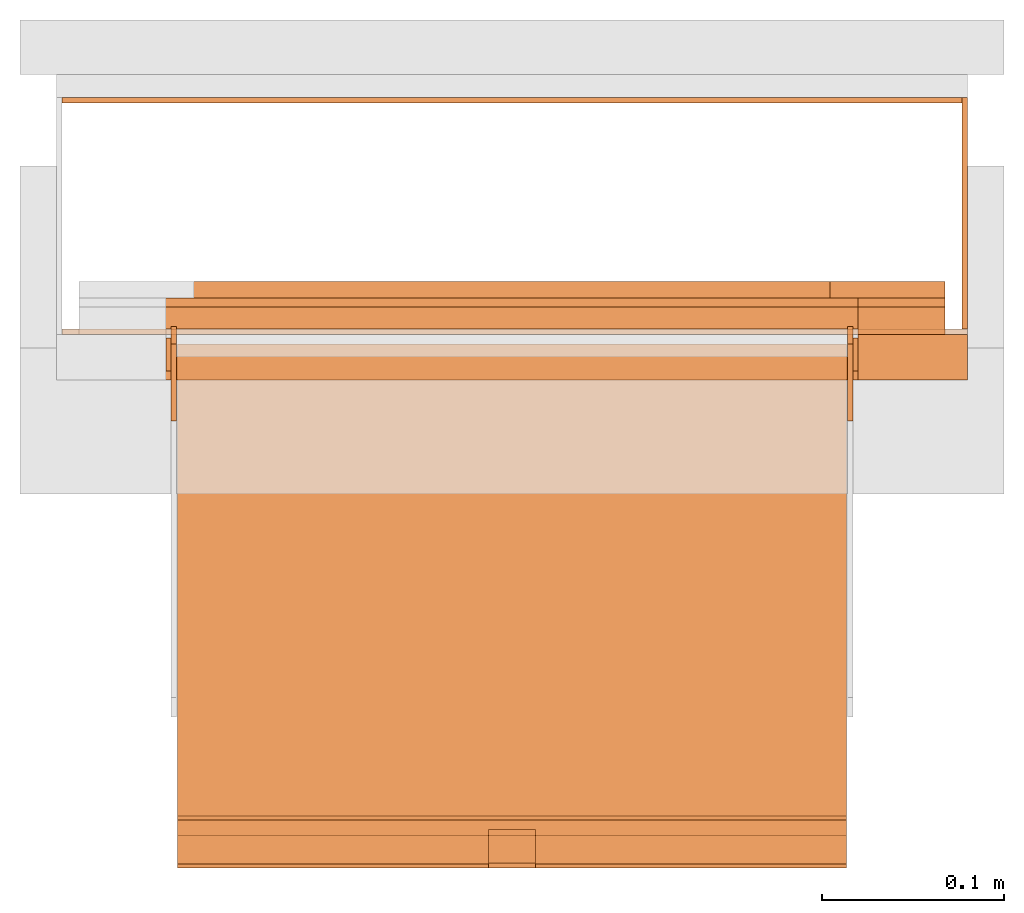
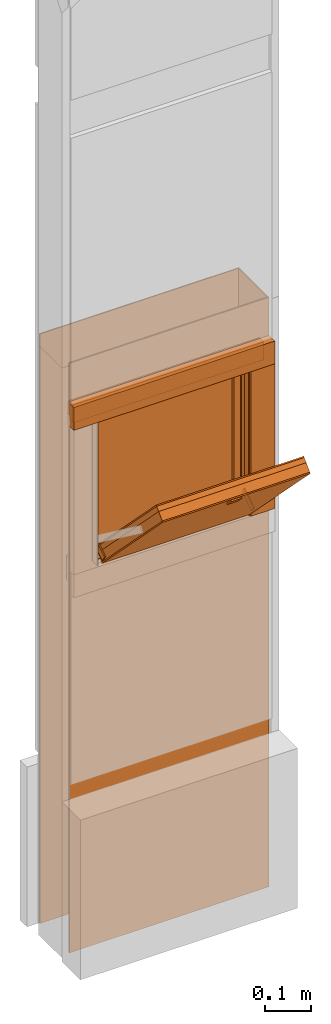
# One storey, part 2 of 3: 20 proxies, 1 opening.
"""IFC2X3 building model written with IfcOpenShell, lengths in metres."""

from ifc_helpers import new_model, entity, si_unit, converted_unit, derived_unit, money_unit, direction, frame, origin_with_axes, origin_2d_with_axis, place, context, subcontext, project, spatial, polyline, rectangle, outline, extrude, boolean, faceted_brep, source, transform, mapped, material, type_object, element, save


model = new_model("IFC2X3")

# Units and contexts
model_context = context("Model", 3, precision=1e-05, world=origin_with_axes(), true_north=direction((0.0, 1.0)))
plan_context = context("Plan", 3, precision=1e-05, world=origin_with_axes(), true_north=direction((0.0, 1.0)))
body_context = subcontext(model_context, "Body", "Model", "MODEL_VIEW")
ifc_project = project(units=[si_unit("LENGTHUNIT", "METRE"), si_unit("AREAUNIT", "SQUARE_METRE"), si_unit("VOLUMEUNIT", "CUBIC_METRE"), converted_unit("PLANEANGLEUNIT", "DEGREE", entity("IfcPlaneAngleMeasure", 0.0174532925199), si_unit("PLANEANGLEUNIT", "RADIAN"), dimensions=[0, 0, 0, 0, 0, 0, 0]), si_unit("SOLIDANGLEUNIT", "STERADIAN"), money_unit("CHF"), converted_unit("TIMEUNIT", "Year", entity("IfcTimeMeasure", 31556926.0), si_unit("TIMEUNIT", "SECOND"), dimensions=[0, 0, 1, 0, 0, 0, 0]), si_unit("MASSUNIT", "GRAM", prefix="KILO"), si_unit("THERMODYNAMICTEMPERATUREUNIT", "DEGREE_CELSIUS"), si_unit("LUMINOUSINTENSITYUNIT", "LUMEN"), si_unit("ENERGYUNIT", "JOULE", prefix="MEGA"), derived_unit("THERMALCONDUCTANCEUNIT", [(si_unit("POWERUNIT", "WATT"), 1), (si_unit("LENGTHUNIT", "METRE"), -1), (si_unit("THERMODYNAMICTEMPERATUREUNIT", "KELVIN"), -1)]), derived_unit("SPECIFICHEATCAPACITYUNIT", [(si_unit("ENERGYUNIT", "JOULE"), 1), (si_unit("MASSUNIT", "GRAM", prefix="KILO"), -1), (si_unit("THERMODYNAMICTEMPERATUREUNIT", "KELVIN"), -1)]), derived_unit("MASSDENSITYUNIT", [(si_unit("MASSUNIT", "GRAM", prefix="KILO"), 1), (si_unit("VOLUMEUNIT", "CUBIC_METRE"), -1)])], contexts=[model_context, plan_context])

# Site, building, storey
site_placement = place(None, origin_with_axes())
site = spatial("IfcSite", under=ifc_project, at=site_placement, CompositionType="ELEMENT")
building_placement = place(site_placement, origin_with_axes())
building = spatial("IfcBuilding", under=site, at=building_placement, CompositionType="ELEMENT")
storey_placement = place(building_placement, frame((0.0, 0.0, 2.96), z_axis=(0.0, 0.0, 1.0), x_axis=(1.0, 0.0, 0.0)))
storey = spatial("IfcBuildingStorey", under=building, at=storey_placement, Name="OG01", CompositionType="ELEMENT", Elevation=2.96)

# Proxies
ifc_material_1 = material(Name="Metall, Stahl")
building_element_proxy_type_1 = type_object("IfcBuildingElementProxyType", Name="Metall, Stahl 3", PredefinedType="NOTDEFINED")
proxy_1_placement = place(storey_placement, frame((9.61522436818, -8.09743070606, -0.4), z_axis=(0.0, 0.0, 1.0), x_axis=(-1.0, 0.0, 0.0)))
element("IfcBuildingElementProxy", 1, at=proxy_1_placement, inside=storey, type_object=building_element_proxy_type_1, material=ifc_material_1, Name="Wand-008", context=body_context, shape_type="CSG", body=[
    boolean("DIFFERENCE", boolean("DIFFERENCE", extrude(outline(polyline([(0.0, 0.0), (0.5, 0.0), (0.5, 0.003), (0.0, 0.003), (0.0, 0.0)])), origin_with_axes(), (0.0, 0.0, 1.0), 1.55), faceted_brep([(0.497, 0.003, 1.55), (0.497, 0.0, 1.55), (0.5, 0.0, 1.55), (0.5, 0.003, 1.55), (0.497, 0.0, 0.0), (0.497, 0.003, 0.0), (0.5, 0.0, 0.0), (0.5, 0.003, 0.0)], [[[0, 1, 2, 3]], [[4, 1, 0, 5]], [[1, 4, 6, 2]], [[2, 6, 7, 3]], [[5, 0, 3, 7]], [[4, 5, 7, 6]]])), faceted_brep([(0.003, 0.0, 0.0), (0.003, 0.0, 1.55), (0.0, 0.0, 1.55), (0.0, 0.0, 0.0), (0.003, 0.003, 1.55), (0.003, 0.003, 0.0), (0.0, 0.003, 1.55), (0.0, 0.003, 0.0)], [[[0, 1, 2, 3]], [[4, 1, 0, 5]], [[1, 4, 6, 2]], [[6, 7, 3, 2]], [[5, 0, 3, 7]], [[4, 5, 7, 6]]])),
])
proxy_2_placement = place(storey_placement, frame((9.61522436818, -8.22743070606, -0.4), z_axis=(0.0, 0.0, 1.0), x_axis=(0.0, 1.0, 0.0)))
element("IfcBuildingElementProxy", 2, at=proxy_2_placement, inside=storey, type_object=building_element_proxy_type_1, material=ifc_material_1, Name="Wand-007", context=body_context, shape_type="CSG", body=[
    boolean("DIFFERENCE", extrude(outline(polyline([(0.0, 0.0), (0.13, 0.0), (0.13, 0.003), (0.0, 0.003), (0.0, 0.0)])), origin_with_axes(), (0.0, 0.0, 1.0), 1.55), faceted_brep([(0.003, 0.0, 0.0), (0.003, 0.0, 1.55), (0.0, 0.0, 1.55), (0.0, 0.0, 0.0), (0.003, 0.003, 1.55), (0.003, 0.003, 0.0), (0.0, 0.003, 1.55), (0.0, 0.003, 0.0)], [[[0, 1, 2, 3]], [[4, 1, 0, 5]], [[1, 4, 6, 2]], [[6, 7, 3, 2]], [[5, 0, 3, 7]], [[4, 5, 7, 6]]])),
])

# Proxy, opening
proxy_3_placement = place(storey_placement, frame((9.11522436818, -8.22743070606, -0.4), z_axis=(0.0, 0.0, 1.0), x_axis=(1.0, 0.0, 0.0)))
proxy_3 = element("IfcBuildingElementProxy", 3, at=proxy_3_placement, inside=storey, type_object=building_element_proxy_type_1, material=ifc_material_1, Name="Wand-006", context=body_context, shape_type="CSG", body=[
    boolean("DIFFERENCE", extrude(outline(polyline([(0.0, 0.0), (0.5, 0.0), (0.5, 0.003), (0.0, 0.003), (0.0, 0.0)])), origin_with_axes(), (0.0, 0.0, 1.0), 1.55), faceted_brep([(0.003, 0.0, 1.55), (0.003, 0.003, 1.55), (0.0, 0.003, 1.55), (0.0, 0.0, 1.55), (0.003, 0.003, 0.0), (0.003, 0.0, 0.0), (0.0, 0.003, 0.0), (0.0, 0.0, 0.0)], [[[0, 1, 2, 3]], [[4, 1, 0, 5]], [[1, 4, 6, 2]], [[2, 6, 7, 3]], [[5, 0, 3, 7]], [[4, 5, 7, 6]]])),
])
opening_placement = place(proxy_3_placement, frame((-9.11522436818, 8.22743070606, -2.56), z_axis=(0.0, 0.0, 1.0), x_axis=(1.0, 0.0, 0.0)))
element("IfcOpeningElement", 4, at=opening_placement, cuts=proxy_3, Name="035", context=body_context, shape_type="SweptSolid", body=[
    extrude(rectangle(XDim=0.38, YDim=0.38, at=origin_2d_with_axis()), frame((9.36522436818, -8.25243070606, 3.76), z_axis=(0.0, -1.0, 0.0), x_axis=(1.0, 0.0, 0.0)), (0.0, 0.0, -1.0), 0.031),
])

# Proxies
ifc_material_2 = material(Name="Metall, Aluminium")
building_element_proxy_type_2 = type_object("IfcBuildingElementProxyType", Name="Metall, Aluminium", PredefinedType="NOTDEFINED")
shared_shape_1 = source(origin_with_axes(), body_context, "Body", "Brep", [
    faceted_brep([(16.1345115895, -3.59726483298, 0.726478855326), (16.1345115895, -3.60026483298, 0.726478855326), (16.1345115895, -3.60026483298, 0.776478855326), (16.1345115895, -3.59726483298, 0.776478855326), (16.1525115895, -3.60026483298, 0.726478855326), (16.1525115895, -3.59726483298, 0.726478855326), (16.1525115895, -3.60026483298, 0.776478855326), (16.1525115895, -3.59726483298, 0.776478855326)], [[[0, 1, 2, 3]], [[4, 1, 0, 5]], [[1, 4, 6, 2]], [[2, 6, 7, 3]], [[0, 3, 7, 5]], [[4, 5, 7, 6]]]),
])
for number, where, z_axis, x_axis, name in (
    (5, (12.7784892012, -16.2173099117, 14.7145311427), (0.0, -0.846133712697, -0.532970674838), (0.0, 0.532970674838, -0.846133712697), "Wand-005"),
    (6, (13.1494892012, -16.2173099117, 14.7145311427), (0.0, -0.846133712697, -0.532970674838), (0.0, 0.532970674838, -0.846133712697), "Wand-005"),
):
    element("IfcBuildingElementProxy", number, at=place(storey_placement, frame(where, z_axis=z_axis, x_axis=x_axis)), inside=storey, type_object=building_element_proxy_type_2, material=ifc_material_2, Name=name, context=body_context, shape_type="MappedRepresentation", body=[
        mapped(shared_shape_1, transform((0.0, 0.0, 0.0))),
    ])
shared_shape_2 = source(origin_with_axes(), body_context, "Body", "Brep", [
    faceted_brep([(16.3888858635, -3.43025891523, 1.114), (16.3888858635, -3.43025891523, 1.14), (16.3888858635, -3.40425891523, 1.14), (16.3888858635, -3.40425891523, 1.114), (16.3928858635, -3.43025891523, 1.114), (16.3928858635, -3.43025891523, 1.14), (16.3928858635, -3.40825891523, 1.14), (16.3928858635, -3.40425891523, 1.14), (16.3928858635, -3.40425891523, 1.114), (16.3928858635, -3.40825891523, 1.114)], [[[0, 1, 2, 3]], [[1, 0, 4]], [[2, 1, 5, 6, 7]], [[3, 2, 7, 8]], [[0, 3, 8, 9, 4]], [[1, 4, 5]], [[6, 5, 4]], [[6, 9, 8, 7]], [[9, 6, 4]]]),
])
proxy_4_placement = place(storey_placement, frame((12.7824832834, 3.98081117247, 11.5470677443), z_axis=(0.0, -0.700249431637, 0.713898265506), x_axis=(0.0, -0.713898265506, -0.700249431637)))
element("IfcBuildingElementProxy", 7, at=proxy_4_placement, inside=storey, type_object=building_element_proxy_type_2, material=ifc_material_2, Name="Wand-007", context=body_context, shape_type="MappedRepresentation", body=[
    mapped(shared_shape_2, transform((0.0, 0.0, 0.0))),
])
ifc_material_3 = material(Name="Holz")
building_element_proxy_type_3 = type_object("IfcBuildingElementProxyType", Name="Holz 15", PredefinedType="NOTDEFINED")
proxy_5_placement = place(storey_placement, frame((9.55522436818, -8.22743070606, 0.61), z_axis=(0.0, 0.0, 1.0), x_axis=(1.0, 0.0, 0.0)))
element("IfcBuildingElementProxy", 8, at=proxy_5_placement, inside=storey, type_object=building_element_proxy_type_3, material=ifc_material_3, Name="Wand-004", context=body_context, shape_type="SweptSolid", body=[
    extrude(outline(polyline([(0.0, 0.0), (0.0475, 0.0), (0.0475, 0.015), (0.0, 0.015), (0.0, 0.0)])), origin_with_axes(), (0.0, 0.0, 1.0), 0.38),
])
proxy_6_placement = place(storey_placement, frame((9.60272436818, -8.21243070606, 0.99), z_axis=(0.0, 0.0, 1.0), x_axis=(-1.0, 0.0, 0.0)))
element("IfcBuildingElementProxy", 9, at=proxy_6_placement, inside=storey, type_object=building_element_proxy_type_3, material=ifc_material_3, Name="Wand-004", context=body_context, shape_type="SweptSolid", body=[
    extrude(outline(polyline([(0.0, 0.0), (0.475, 0.0), (0.475, 0.015), (0.0, 0.015), (0.0, 0.0)])), origin_with_axes(), (0.0, 0.0, 1.0), 0.0475),
])
building_element_proxy_type_4 = type_object("IfcBuildingElementProxyType", Name="Holz 5", PredefinedType="NOTDEFINED")
proxy_7_placement = place(storey_placement, frame((9.55522436818, -8.21243070606, 0.6), z_axis=(0.0, 0.0, 1.0), x_axis=(1.0, 0.0, 0.0)))
element("IfcBuildingElementProxy", 10, at=proxy_7_placement, inside=storey, type_object=building_element_proxy_type_4, material=ifc_material_3, Name="Wand-004", context=body_context, shape_type="SweptSolid", body=[
    extrude(outline(polyline([(0.0, 0.0), (0.0475, 0.0), (0.0475, 0.005), (0.0, 0.005), (0.0, 0.0)])), origin_with_axes(), (0.0, 0.0, 1.0), 0.4),
])
proxy_8_placement = place(storey_placement, frame((9.60272436818, -8.21243070606, 1.0), z_axis=(0.0, 0.0, 1.0), x_axis=(-1.0, 0.0, 0.0)))
element("IfcBuildingElementProxy", 11, at=proxy_8_placement, inside=storey, type_object=building_element_proxy_type_4, material=ifc_material_3, Name="Wand-004", context=body_context, shape_type="SweptSolid", body=[
    extrude(outline(polyline([(0.0, -0.005), (0.475, -0.005), (0.475, 0.0), (0.0, 0.0), (0.0, -0.005)])), origin_with_axes(), (0.0, 0.0, 1.0), 0.0375),
])
building_element_proxy_type_5 = type_object("IfcBuildingElementProxyType", Name="Holz 25", PredefinedType="NOTDEFINED")
proxy_9_placement = place(storey_placement, frame((9.55522436818, -8.25243070606, 0.61), z_axis=(0.0, 0.0, 1.0), x_axis=(1.0, 0.0, 0.0)))
element("IfcBuildingElementProxy", 12, at=proxy_9_placement, inside=storey, type_object=building_element_proxy_type_5, material=ifc_material_3, Name="Wand-004", context=body_context, shape_type="SweptSolid", body=[
    extrude(outline(polyline([(0.0, 0.0), (0.06, 0.0), (0.06, 0.025), (0.0, 0.025), (0.0, 0.0)])), origin_with_axes(), (0.0, 0.0, 1.0), 0.38),
])
proxy_10_placement = place(storey_placement, frame((9.61522436818, -8.22743070606, 0.99), z_axis=(0.0, 0.0, 1.0), x_axis=(-1.0, 0.0, 0.0)))
element("IfcBuildingElementProxy", 13, at=proxy_10_placement, inside=storey, type_object=building_element_proxy_type_5, material=ifc_material_3, Name="Wand-004", context=body_context, shape_type="SweptSolid", body=[
    extrude(outline(polyline([(0.0, 0.0), (0.5, 0.0), (0.5, 0.025), (0.0, 0.025), (0.0, 0.0)])), origin_with_axes(), (0.0, 0.0, 1.0), 0.06),
])
building_element_proxy_type_6 = type_object("IfcBuildingElementProxyType", Name="Metall, Aluminium 3", PredefinedType="NOTDEFINED")
proxy_11_placement = place(storey_placement, frame((9.55522436818, -8.22943070606, 0.61), z_axis=(0.0, 0.0, 1.0), x_axis=(0.0, -1.0, 0.0)))
element("IfcBuildingElementProxy", 14, at=proxy_11_placement, inside=storey, type_object=building_element_proxy_type_6, material=ifc_material_2, Name="Wand-006", context=body_context, shape_type="SweptSolid", body=[
    extrude(outline(polyline([(0.0, -0.003), (0.018, -0.003), (0.018, 0.0), (0.0, 0.0), (0.0, -0.003)])), origin_with_axes(), (0.0, 0.0, 1.0), 0.393521144674),
])
proxy_12_placement = place(storey_placement, frame((9.17522436818, -8.22943070606, 0.61), z_axis=(0.0, 0.0, 1.0), x_axis=(0.0, -1.0, 0.0)))
element("IfcBuildingElementProxy", 15, at=proxy_12_placement, inside=storey, type_object=building_element_proxy_type_6, material=ifc_material_2, Name="Wand-006", context=body_context, shape_type="SweptSolid", body=[
    extrude(outline(polyline([(0.0, 0.0), (0.018, 0.0), (0.018, 0.003), (0.0, 0.003), (0.0, 0.0)])), origin_with_axes(), (0.0, 0.0, 1.0), 0.393521144674),
])
building_element_proxy_type_7 = type_object("IfcBuildingElementProxyType", Name="Holz", PredefinedType="NOTDEFINED")
shared_shape_3 = source(origin_with_axes(), body_context, "Body", "Brep", [
    faceted_brep([(16.0840766769, -3.65867330347, 1.10947885533), (16.0840766769, -3.29167330347, 1.10947885533), (16.0840766769, -3.29167330347, 0.736478855326), (16.0840766769, -3.65867330347, 0.736478855326), (16.1060766769, -3.65867330347, 1.10947885533), (16.1060766769, -3.29167330347, 1.10947885533), (16.1060766769, -3.29167330347, 0.736478855326), (16.1060766769, -3.65867330347, 0.736478855326)], [[[0, 1, 2, 3]], [[1, 0, 4, 5]], [[2, 1, 5, 6]], [[3, 2, 6, 7]], [[0, 3, 7, 4]], [[4, 7, 6, 5]]]),
])
proxy_13_placement = place(storey_placement, frame((12.8403976717, 3.75690888182, 11.375802015), z_axis=(0.0, -0.700249431637, 0.713898265506), x_axis=(0.0, -0.713898265506, -0.700249431637)))
element("IfcBuildingElementProxy", 16, at=proxy_13_placement, inside=storey, type_object=building_element_proxy_type_7, material=ifc_material_3, Name="Wand-004", context=body_context, shape_type="MappedRepresentation", body=[
    mapped(shared_shape_3, transform((0.0, 0.0, 0.0))),
])
ifc_material_4 = material(Name="Gipsplatte horizontal")
building_element_proxy_type_8 = type_object("IfcBuildingElementProxyType", Name="Gipsplatte horizontal", PredefinedType="NOTDEFINED")
shared_shape_4 = source(origin_with_axes(), body_context, "Body", "Brep", [
    faceted_brep([(16.0720766769, -3.65867330347, 1.10947885533), (16.0720766769, -3.29167330347, 1.10947885533), (16.0720766769, -3.29167330347, 0.736478855326), (16.0720766769, -3.65867330347, 0.736478855326), (16.0840766769, -3.65867330347, 1.10947885533), (16.0840766769, -3.29167330347, 1.10947885533), (16.0840766769, -3.29167330347, 0.736478855326), (16.0840766769, -3.65867330347, 0.736478855326)], [[[0, 1, 2, 3]], [[1, 0, 4, 5]], [[2, 1, 5, 6]], [[3, 2, 6, 7]], [[0, 3, 7, 4]], [[4, 7, 6, 5]]]),
])
proxy_14_placement = place(storey_placement, frame((12.8403976717, 3.75690888182, 11.375802015), z_axis=(0.0, -0.700249431637, 0.713898265506), x_axis=(0.0, -0.713898265506, -0.700249431637)))
element("IfcBuildingElementProxy", 17, at=proxy_14_placement, inside=storey, type_object=building_element_proxy_type_8, material=ifc_material_4, Name="Wand-004", context=body_context, shape_type="MappedRepresentation", body=[
    mapped(shared_shape_4, transform((0.0, 0.0, 0.0))),
])
building_element_proxy_type_9 = type_object("IfcBuildingElementProxyType", Name="Holz 9", PredefinedType="NOTDEFINED")
proxy_15_placement = place(storey_placement, frame((9.53972436818, -8.20743070606, 0.625), z_axis=(0.0, 0.0, 1.0), x_axis=(1.0, 0.0, 0.0)))
element("IfcBuildingElementProxy", 18, at=proxy_15_placement, inside=storey, type_object=building_element_proxy_type_9, material=ifc_material_3, Name="Wand-004", context=body_context, shape_type="SweptSolid", body=[
    extrude(outline(polyline([(0.0, 0.0), (0.063, 0.0), (0.063, 0.009), (0.0, 0.009), (0.0, 0.0)])), origin_with_axes(), (0.0, 0.0, 1.0), 0.35),
])
proxy_16_placement = place(storey_placement, frame((9.60272436818, -8.20743070606, 0.5625), z_axis=(0.0, 0.0, 1.0), x_axis=(-1.0, 0.0, 0.0)))
element("IfcBuildingElementProxy", 19, at=proxy_16_placement, inside=storey, type_object=building_element_proxy_type_9, material=ifc_material_3, Name="Wand-004", context=body_context, shape_type="SweptSolid", body=[
    extrude(outline(polyline([(0.0, -0.009), (0.475, -0.009), (0.475, 0.0), (0.0, 0.0), (0.0, -0.009)])), origin_with_axes(), (0.0, 0.0, 1.0), 0.0625),
])
shared_shape_5 = source(origin_with_axes(), body_context, "Body", "Brep", [
    faceted_brep([(16.1060766769, -3.29167330347, 0.736478855326), (16.1060766769, -3.65867330347, 0.736478855326), (16.1060766769, -3.65867330347, 1.10947885533), (16.1060766769, -3.29167330347, 1.10947885533), (16.1091136769, -3.29167330347, 0.736478855326), (16.1091136769, -3.65867330347, 0.736478855326), (16.1091136769, -3.65867330347, 1.10947885533), (16.1091136769, -3.29167330347, 1.10947885533)], [[[0, 1, 2, 3]], [[1, 0, 4, 5]], [[2, 1, 5, 6]], [[3, 2, 6, 7]], [[0, 3, 7, 4]], [[5, 4, 7, 6]]]),
])
proxy_17_placement = place(storey_placement, frame((12.8403976717, 3.75690888182, 11.375802015), z_axis=(0.0, -0.700249431637, 0.713898265506), x_axis=(0.0, -0.713898265506, -0.700249431637)))
element("IfcBuildingElementProxy", 20, at=proxy_17_placement, inside=storey, type_object=building_element_proxy_type_2, material=ifc_material_2, Name="Wand-004", context=body_context, shape_type="MappedRepresentation", body=[
    mapped(shared_shape_5, transform((0.0, 0.0, 0.0))),
])
shared_shape_6 = source(origin_with_axes(), body_context, "Body", "Brep", [
    faceted_brep([(16.0690396769, -3.29167330347, 0.736478855326), (16.0690396769, -3.65867330347, 0.736478855326), (16.0690396769, -3.65867330347, 1.10947885533), (16.0690396769, -3.29167330347, 1.10947885533), (16.0720766769, -3.29167330347, 0.736478855326), (16.0720766769, -3.65867330347, 0.736478855326), (16.0720766769, -3.65867330347, 1.10947885533), (16.0720766769, -3.29167330347, 1.10947885533)], [[[0, 1, 2, 3]], [[1, 0, 4, 5]], [[2, 1, 5, 6]], [[3, 2, 6, 7]], [[0, 3, 7, 4]], [[5, 4, 7, 6]]]),
])
proxy_18_placement = place(storey_placement, frame((12.8403976717, 3.75690888182, 11.375802015), z_axis=(0.0, -0.700249431637, 0.713898265506), x_axis=(0.0, -0.713898265506, -0.700249431637)))
element("IfcBuildingElementProxy", 21, at=proxy_18_placement, inside=storey, type_object=building_element_proxy_type_2, material=ifc_material_2, Name="Wand-004", context=body_context, shape_type="MappedRepresentation", body=[
    mapped(shared_shape_6, transform((0.0, 0.0, 0.0))),
])

save(model, "model.ifc")
